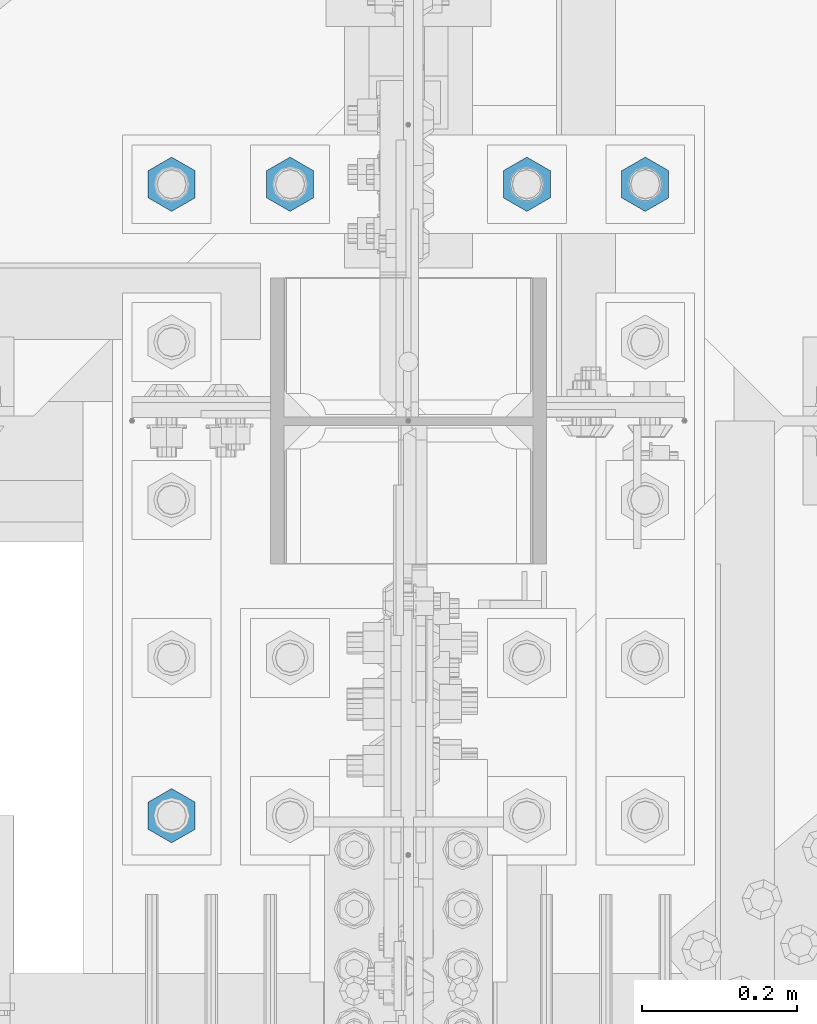
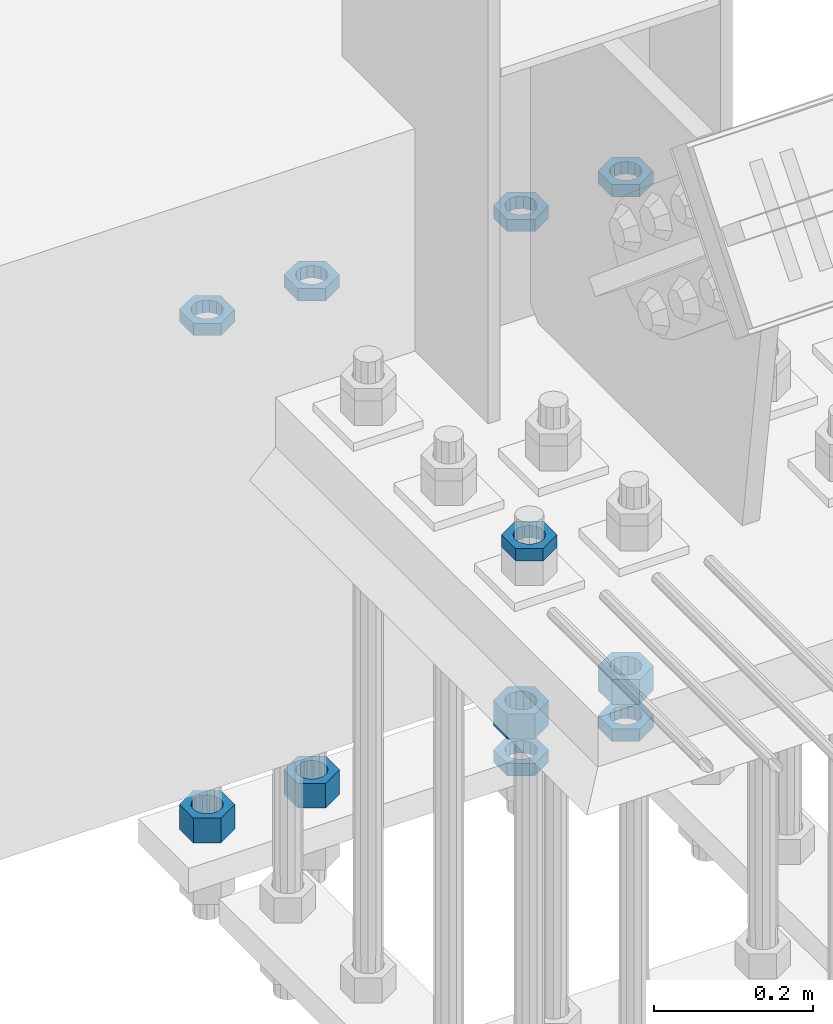
# One storey, part 2843 of 3843: 11 beams, 1 element without a shape of its own.
"""IFC2X3 building model written with IfcOpenShell, lengths in millimetres."""

from ifc_helpers import new_model, si_unit, frame, origin_with_axes, place, context, subcontext, project, spatial, faceted_brep, material, type_object, element, aggregate, save


model = new_model("IFC2X3")

# Units and contexts
model_context = context("Model", 3, precision=1e-05, world=origin_with_axes())
body_context = subcontext(model_context, "Body", "Model", "MODEL_VIEW")
ifc_project = project(units=[si_unit("LENGTHUNIT", "METRE", prefix="MILLI"), si_unit("AREAUNIT", "SQUARE_METRE"), si_unit("VOLUMEUNIT", "CUBIC_METRE"), si_unit("MASSUNIT", "GRAM", prefix="KILO"), si_unit("TIMEUNIT", "SECOND"), si_unit("PLANEANGLEUNIT", "RADIAN"), si_unit("SOLIDANGLEUNIT", "STERADIAN"), si_unit("THERMODYNAMICTEMPERATUREUNIT", "DEGREE_CELSIUS"), si_unit("LUMINOUSINTENSITYUNIT", "LUMEN")], contexts=[model_context])

# Site, building, storey
site_placement = place(None, origin_with_axes())
site = spatial("IfcSite", under=ifc_project, at=site_placement, CompositionType="ELEMENT")
building_placement = place(site_placement, origin_with_axes())
building = spatial("IfcBuilding", under=site, at=building_placement, Name="Undefined", CompositionType="ELEMENT")
storey_placement = place(building_placement, origin_with_axes())
storey = spatial("IfcBuildingStorey", under=building, at=storey_placement, Name="Undefined", CompositionType="ELEMENT", Elevation=0.0)

# Assembly, beams
assembly_placement = place(storey_placement, origin_with_axes())
assembly = element("IfcElementAssembly", 1, at=assembly_placement, inside=storey, Name="TEMPLATE", AssemblyPlace="NOTDEFINED", PredefinedType="RIGID_FRAME")
ifc_material = material(Name="STEEL/A572-50")
beam_type_1 = type_object("IfcBeamType", Name="1-1/2_HEAVY_HEX_NUT", PredefinedType="NOTDEFINED")
beam_1_placement = place(assembly_placement, frame((76708.0, 25920.7, 29298.9000015259), z_axis=(1.0, 0.0, 0.0), x_axis=(0.0, 0.0, -1.0)))
beam_1 = element("IfcBeam", 2, at=beam_1_placement, type_object=beam_type_1, material=ifc_material, Name="NUT", ObjectType="1-1/2_HEAVY_HEX_NUT", context=body_context, shape_type="Brep", body=[
    faceted_brep([(0.0, -34.9199981689453, 0.0), (0.0, -17.4599990844727, -30.25), (38.0999999999985, -17.4599990844727, -30.25), (38.0999999999985, -34.9199981689453, 0.0), (0.0, 17.4599990844727, -30.25), (38.0999999999985, 17.4599990844727, -30.25), (0.0, 34.9199981689453, 0.0), (38.0999999999985, 34.9199981689453, 0.0), (0.0, 17.4599990844727, 30.25), (38.0999999999985, 17.4599990844727, 30.25), (0.0, -17.4599990844727, 30.25), (38.0999999999985, -17.4599990844727, 30.25), (0.0, 0.0, 20.6399993896484), (0.0, 8.9553601105581, 18.5959968835959), (38.0999999999985, 8.9553601105581, 18.5959968835959), (38.0999999999985, 0.0, 20.6399993896484), (0.0, 16.1370013209525, 12.8688291298167), (38.0999999999985, 16.1370013209525, 12.8688291298167), (0.0, 20.1225115123816, 4.59283194104501), (38.0999999999985, 20.1225115123816, 4.59283194104501), (0.0, 20.1225115123816, -4.59283194104501), (38.0999999999985, 20.1225115123816, -4.59283194104501), (0.0, 16.1370013209525, -12.8688291298167), (38.0999999999985, 16.1370013209525, -12.8688291298167), (0.0, 8.9553601105581, -18.5959968835959), (38.0999999999985, 8.9553601105581, -18.5959968835959), (0.0, 0.0, -20.6399993896484), (38.0999999999985, 0.0, -20.6399993896484), (0.0, -8.9553601105581, -18.5959968835959), (38.0999999999985, -8.9553601105581, -18.5959968835959), (0.0, -16.1370013209525, -12.8688291298167), (38.0999999999985, -16.1370013209525, -12.8688291298167), (0.0, -20.1225115123816, -4.59283194104501), (38.0999999999985, -20.1225115123816, -4.59283194104501), (0.0, -20.1225115123816, 4.59283194104501), (38.0999999999985, -20.1225115123816, 4.59283194104501), (0.0, -16.1370013209525, 12.8688291298167), (38.0999999999985, -16.1370013209525, 12.8688291298167), (0.0, -8.9553601105581, 18.5959968835959), (38.0999999999985, -8.9553601105581, 18.5959968835959)], [[[0, 1, 2, 3]], [[1, 4, 5, 2]], [[4, 6, 7, 5]], [[6, 8, 9, 7]], [[8, 10, 11, 9]], [[10, 0, 3, 11]], [[12, 13, 14, 15]], [[13, 16, 17, 14]], [[16, 18, 19, 17]], [[18, 20, 21, 19]], [[20, 22, 23, 21]], [[22, 24, 25, 23]], [[24, 26, 27, 25]], [[26, 28, 29, 27]], [[28, 30, 31, 29]], [[30, 32, 33, 31]], [[32, 34, 35, 33]], [[34, 36, 37, 35]], [[36, 38, 39, 37]], [[38, 12, 15, 39]], [[5, 7, 9, 11, 3, 2], [17, 19, 21, 23, 25, 27, 29, 31, 33, 35, 37, 39, 15, 14]], [[10, 8, 6, 4, 1, 0], [38, 36, 34, 32, 30, 28, 26, 24, 22, 20, 18, 16, 13, 12]]]),
])
beam_2_placement = place(assembly_placement, frame((76860.4, 25920.7, 29298.9000015259), z_axis=(1.0, 0.0, 0.0), x_axis=(0.0, 0.0, -1.0)))
beam_2 = element("IfcBeam", 3, at=beam_2_placement, type_object=beam_type_1, material=ifc_material, Name="NUT", ObjectType="1-1/2_HEAVY_HEX_NUT", context=body_context, shape_type="Brep", body=[
    faceted_brep([(0.0, -34.9199981689453, 0.0), (0.0, -17.4599990844727, -30.25), (38.0999999999985, -17.4599990844727, -30.25), (38.0999999999985, -34.9199981689453, 0.0), (0.0, 17.4599990844727, -30.25), (38.0999999999985, 17.4599990844727, -30.25), (0.0, 34.9199981689453, 0.0), (38.0999999999985, 34.9199981689453, 0.0), (0.0, 17.4599990844727, 30.25), (38.0999999999985, 17.4599990844727, 30.25), (0.0, -17.4599990844727, 30.25), (38.0999999999985, -17.4599990844727, 30.25), (0.0, 0.0, 20.6399993896484), (0.0, 8.9553601105581, 18.5959968835959), (38.0999999999985, 8.9553601105581, 18.5959968835959), (38.0999999999985, 0.0, 20.6399993896484), (0.0, 16.1370013209525, 12.8688291298167), (38.0999999999985, 16.1370013209525, 12.8688291298167), (0.0, 20.1225115123816, 4.59283194104501), (38.0999999999985, 20.1225115123816, 4.59283194104501), (0.0, 20.1225115123816, -4.59283194104501), (38.0999999999985, 20.1225115123816, -4.59283194104501), (0.0, 16.1370013209525, -12.8688291298167), (38.0999999999985, 16.1370013209525, -12.8688291298167), (0.0, 8.9553601105581, -18.5959968835959), (38.0999999999985, 8.9553601105581, -18.5959968835959), (0.0, 0.0, -20.6399993896484), (38.0999999999985, 0.0, -20.6399993896484), (0.0, -8.9553601105581, -18.5959968835959), (38.0999999999985, -8.9553601105581, -18.5959968835959), (0.0, -16.1370013209525, -12.8688291298167), (38.0999999999985, -16.1370013209525, -12.8688291298167), (0.0, -20.1225115123816, -4.59283194104501), (38.0999999999985, -20.1225115123816, -4.59283194104501), (0.0, -20.1225115123816, 4.59283194104501), (38.0999999999985, -20.1225115123816, 4.59283194104501), (0.0, -16.1370013209525, 12.8688291298167), (38.0999999999985, -16.1370013209525, 12.8688291298167), (0.0, -8.9553601105581, 18.5959968835959), (38.0999999999985, -8.9553601105581, 18.5959968835959)], [[[0, 1, 2, 3]], [[1, 4, 5, 2]], [[4, 6, 7, 5]], [[6, 8, 9, 7]], [[8, 10, 11, 9]], [[10, 0, 3, 11]], [[12, 13, 14, 15]], [[13, 16, 17, 14]], [[16, 18, 19, 17]], [[18, 20, 21, 19]], [[20, 22, 23, 21]], [[22, 24, 25, 23]], [[24, 26, 27, 25]], [[26, 28, 29, 27]], [[28, 30, 31, 29]], [[30, 32, 33, 31]], [[32, 34, 35, 33]], [[34, 36, 37, 35]], [[36, 38, 39, 37]], [[38, 12, 15, 39]], [[5, 7, 9, 11, 3, 2], [17, 19, 21, 23, 25, 27, 29, 31, 33, 35, 37, 39, 15, 14]], [[10, 8, 6, 4, 1, 0], [38, 36, 34, 32, 30, 28, 26, 24, 22, 20, 18, 16, 13, 12]]]),
])
beam_3_placement = place(assembly_placement, frame((77165.2, 25920.7, 29298.9000015259), z_axis=(1.0, 0.0, 0.0), x_axis=(0.0, 0.0, -1.0)))
beam_3 = element("IfcBeam", 4, at=beam_3_placement, type_object=beam_type_1, material=ifc_material, Name="NUT", ObjectType="1-1/2_HEAVY_HEX_NUT", context=body_context, shape_type="Brep", body=[
    faceted_brep([(0.0, -34.9199981689453, 0.0), (0.0, -17.4599990844727, -30.25), (38.0999999999985, -17.4599990844727, -30.25), (38.0999999999985, -34.9199981689453, 0.0), (0.0, 17.4599990844727, -30.25), (38.0999999999985, 17.4599990844727, -30.25), (0.0, 34.9199981689453, 0.0), (38.0999999999985, 34.9199981689453, 0.0), (0.0, 17.4599990844727, 30.25), (38.0999999999985, 17.4599990844727, 30.25), (0.0, -17.4599990844727, 30.25), (38.0999999999985, -17.4599990844727, 30.25), (0.0, 0.0, 20.6399993896484), (0.0, 8.9553601105581, 18.5959968835959), (38.0999999999985, 8.9553601105581, 18.5959968835959), (38.0999999999985, 0.0, 20.6399993896484), (0.0, 16.1370013209525, 12.8688291298167), (38.0999999999985, 16.1370013209525, 12.8688291298167), (0.0, 20.1225115123816, 4.59283194104501), (38.0999999999985, 20.1225115123816, 4.59283194104501), (0.0, 20.1225115123816, -4.59283194104501), (38.0999999999985, 20.1225115123816, -4.59283194104501), (0.0, 16.1370013209525, -12.8688291298167), (38.0999999999985, 16.1370013209525, -12.8688291298167), (0.0, 8.9553601105581, -18.5959968835959), (38.0999999999985, 8.9553601105581, -18.5959968835959), (0.0, 0.0, -20.6399993896484), (38.0999999999985, 0.0, -20.6399993896484), (0.0, -8.9553601105581, -18.5959968835959), (38.0999999999985, -8.9553601105581, -18.5959968835959), (0.0, -16.1370013209525, -12.8688291298167), (38.0999999999985, -16.1370013209525, -12.8688291298167), (0.0, -20.1225115123816, -4.59283194104501), (38.0999999999985, -20.1225115123816, -4.59283194104501), (0.0, -20.1225115123816, 4.59283194104501), (38.0999999999985, -20.1225115123816, 4.59283194104501), (0.0, -16.1370013209525, 12.8688291298167), (38.0999999999985, -16.1370013209525, 12.8688291298167), (0.0, -8.9553601105581, 18.5959968835959), (38.0999999999985, -8.9553601105581, 18.5959968835959)], [[[0, 1, 2, 3]], [[1, 4, 5, 2]], [[4, 6, 7, 5]], [[6, 8, 9, 7]], [[8, 10, 11, 9]], [[10, 0, 3, 11]], [[12, 13, 14, 15]], [[13, 16, 17, 14]], [[16, 18, 19, 17]], [[18, 20, 21, 19]], [[20, 22, 23, 21]], [[22, 24, 25, 23]], [[24, 26, 27, 25]], [[26, 28, 29, 27]], [[28, 30, 31, 29]], [[30, 32, 33, 31]], [[32, 34, 35, 33]], [[34, 36, 37, 35]], [[36, 38, 39, 37]], [[38, 12, 15, 39]], [[5, 7, 9, 11, 3, 2], [17, 19, 21, 23, 25, 27, 29, 31, 33, 35, 37, 39, 15, 14]], [[10, 8, 6, 4, 1, 0], [38, 36, 34, 32, 30, 28, 26, 24, 22, 20, 18, 16, 13, 12]]]),
])
beam_4_placement = place(assembly_placement, frame((77317.6, 25920.7, 29298.9000015259), z_axis=(1.0, 0.0, 0.0), x_axis=(0.0, 0.0, -1.0)))
beam_4 = element("IfcBeam", 5, at=beam_4_placement, type_object=beam_type_1, material=ifc_material, Name="NUT", ObjectType="1-1/2_HEAVY_HEX_NUT", context=body_context, shape_type="Brep", body=[
    faceted_brep([(0.0, -34.9199981689453, 0.0), (0.0, -17.4599990844727, -30.25), (38.0999999999985, -17.4599990844727, -30.25), (38.0999999999985, -34.9199981689453, 0.0), (0.0, 17.4599990844727, -30.25), (38.0999999999985, 17.4599990844727, -30.25), (0.0, 34.9199981689453, 0.0), (38.0999999999985, 34.9199981689453, 0.0), (0.0, 17.4599990844727, 30.25), (38.0999999999985, 17.4599990844727, 30.25), (0.0, -17.4599990844727, 30.25), (38.0999999999985, -17.4599990844727, 30.25), (0.0, 0.0, 20.6399993896484), (0.0, 8.9553601105581, 18.5959968835959), (38.0999999999985, 8.9553601105581, 18.5959968835959), (38.0999999999985, 0.0, 20.6399993896484), (0.0, 16.1370013209525, 12.8688291298167), (38.0999999999985, 16.1370013209525, 12.8688291298167), (0.0, 20.1225115123816, 4.59283194104501), (38.0999999999985, 20.1225115123816, 4.59283194104501), (0.0, 20.1225115123816, -4.59283194104501), (38.0999999999985, 20.1225115123816, -4.59283194104501), (0.0, 16.1370013209525, -12.8688291298167), (38.0999999999985, 16.1370013209525, -12.8688291298167), (0.0, 8.9553601105581, -18.5959968835959), (38.0999999999985, 8.9553601105581, -18.5959968835959), (0.0, 0.0, -20.6399993896484), (38.0999999999985, 0.0, -20.6399993896484), (0.0, -8.9553601105581, -18.5959968835959), (38.0999999999985, -8.9553601105581, -18.5959968835959), (0.0, -16.1370013209525, -12.8688291298167), (38.0999999999985, -16.1370013209525, -12.8688291298167), (0.0, -20.1225115123816, -4.59283194104501), (38.0999999999985, -20.1225115123816, -4.59283194104501), (0.0, -20.1225115123816, 4.59283194104501), (38.0999999999985, -20.1225115123816, 4.59283194104501), (0.0, -16.1370013209525, 12.8688291298167), (38.0999999999985, -16.1370013209525, 12.8688291298167), (0.0, -8.9553601105581, 18.5959968835959), (38.0999999999985, -8.9553601105581, 18.5959968835959)], [[[0, 1, 2, 3]], [[1, 4, 5, 2]], [[4, 6, 7, 5]], [[6, 8, 9, 7]], [[8, 10, 11, 9]], [[10, 0, 3, 11]], [[12, 13, 14, 15]], [[13, 16, 17, 14]], [[16, 18, 19, 17]], [[18, 20, 21, 19]], [[20, 22, 23, 21]], [[22, 24, 25, 23]], [[24, 26, 27, 25]], [[26, 28, 29, 27]], [[28, 30, 31, 29]], [[30, 32, 33, 31]], [[32, 34, 35, 33]], [[34, 36, 37, 35]], [[36, 38, 39, 37]], [[38, 12, 15, 39]], [[5, 7, 9, 11, 3, 2], [17, 19, 21, 23, 25, 27, 29, 31, 33, 35, 37, 39, 15, 14]], [[10, 8, 6, 4, 1, 0], [38, 36, 34, 32, 30, 28, 26, 24, 22, 20, 18, 16, 13, 12]]]),
])
beam_type_2 = type_object("IfcBeamType", Name="1-1/2_HALF_NUT", PredefinedType="NOTDEFINED")
beam_5_placement = place(assembly_placement, frame((77165.2, 25920.7, 30060.9), z_axis=(1.0, 0.0, 0.0), x_axis=(0.0, 0.0, -1.0)))
beam_5 = element("IfcBeam", 6, at=beam_5_placement, type_object=beam_type_2, material=ifc_material, Name="NUT", ObjectType="1-1/2_HALF_NUT", context=body_context, shape_type="Brep", body=[
    faceted_brep([(0.0, -34.9199981689453, 0.0), (0.0, -17.4599990844727, -30.25), (19.0500000000029, -17.4599990844727, -30.25), (19.0500000000029, -34.9199981689453, 0.0), (0.0, 17.4599990844727, -30.25), (19.0500000000029, 17.4599990844727, -30.25), (0.0, 34.9199981689453, 0.0), (19.0500000000029, 34.9199981689453, 0.0), (0.0, 17.4599990844727, 30.25), (19.0500000000029, 17.4599990844727, 30.25), (0.0, -17.4599990844727, 30.25), (19.0500000000029, -17.4599990844727, 30.25), (0.0, 0.0, 20.6399993896484), (0.0, 8.9553601105581, 18.5959968835959), (19.0500000000029, 8.95536011056538, 18.5959968835959), (19.0500000000029, 0.0, 20.6399993896484), (0.0, 16.1370013209525, 12.8688291298167), (19.0500000000029, 16.1370013209489, 12.8688291298167), (0.0, 20.1225115123816, 4.59283194104501), (19.0500000000029, 20.1225115123852, 4.59283194104501), (0.0, 20.1225115123816, -4.59283194104501), (19.0500000000029, 20.1225115123852, -4.59283194104501), (0.0, 16.1370013209525, -12.8688291298167), (19.0500000000029, 16.1370013209489, -12.8688291298167), (0.0, 8.9553601105581, -18.5959968835959), (19.0500000000029, 8.95536011056538, -18.5959968835959), (0.0, 0.0, -20.6399993896484), (19.0500000000029, 0.0, -20.6399993896484), (0.0, -8.9553601105581, -18.5959968835959), (19.0500000000029, -8.95536011056538, -18.5959968835959), (0.0, -16.1370013209525, -12.8688291298167), (19.0500000000029, -16.1370013209489, -12.8688291298167), (0.0, -20.1225115123816, -4.59283194104501), (19.0500000000029, -20.1225115123852, -4.59283194104501), (0.0, -20.1225115123816, 4.59283194104501), (19.0500000000029, -20.1225115123852, 4.59283194104501), (0.0, -16.1370013209525, 12.8688291298167), (19.0500000000029, -16.1370013209489, 12.8688291298167), (0.0, -8.9553601105581, 18.5959968835959), (19.0500000000029, -8.95536011056538, 18.5959968835959)], [[[0, 1, 2, 3]], [[1, 4, 5, 2]], [[4, 6, 7, 5]], [[6, 8, 9, 7]], [[8, 10, 11, 9]], [[10, 0, 3, 11]], [[12, 13, 14, 15]], [[13, 16, 17, 14]], [[16, 18, 19, 17]], [[18, 20, 21, 19]], [[20, 22, 23, 21]], [[22, 24, 25, 23]], [[24, 26, 27, 25]], [[26, 28, 29, 27]], [[28, 30, 31, 29]], [[30, 32, 33, 31]], [[32, 34, 35, 33]], [[34, 36, 37, 35]], [[36, 38, 39, 37]], [[38, 12, 15, 39]], [[5, 7, 9, 11, 3, 2], [17, 19, 21, 23, 25, 27, 29, 31, 33, 35, 37, 39, 15, 14]], [[10, 8, 6, 4, 1, 0], [38, 36, 34, 32, 30, 28, 26, 24, 22, 20, 18, 16, 13, 12]]]),
])
beam_6_placement = place(assembly_placement, frame((77317.6, 25920.7, 30060.9), z_axis=(1.0, 0.0, 0.0), x_axis=(0.0, 0.0, -1.0)))
beam_6 = element("IfcBeam", 7, at=beam_6_placement, type_object=beam_type_2, material=ifc_material, Name="NUT", ObjectType="1-1/2_HALF_NUT", context=body_context, shape_type="Brep", body=[
    faceted_brep([(0.0, -34.9199981689453, 0.0), (0.0, -17.4599990844727, -30.25), (19.0500000000029, -17.4599990844727, -30.25), (19.0500000000029, -34.9199981689453, 0.0), (0.0, 17.4599990844727, -30.25), (19.0500000000029, 17.4599990844727, -30.25), (0.0, 34.9199981689453, 0.0), (19.0500000000029, 34.9199981689453, 0.0), (0.0, 17.4599990844727, 30.25), (19.0500000000029, 17.4599990844727, 30.25), (0.0, -17.4599990844727, 30.25), (19.0500000000029, -17.4599990844727, 30.25), (0.0, 0.0, 20.6399993896484), (0.0, 8.9553601105581, 18.5959968835959), (19.0500000000029, 8.95536011056538, 18.5959968835959), (19.0500000000029, 0.0, 20.6399993896484), (0.0, 16.1370013209525, 12.8688291298167), (19.0500000000029, 16.1370013209489, 12.8688291298167), (0.0, 20.1225115123816, 4.59283194104501), (19.0500000000029, 20.1225115123852, 4.59283194104501), (0.0, 20.1225115123816, -4.59283194104501), (19.0500000000029, 20.1225115123852, -4.59283194104501), (0.0, 16.1370013209525, -12.8688291298167), (19.0500000000029, 16.1370013209489, -12.8688291298167), (0.0, 8.9553601105581, -18.5959968835959), (19.0500000000029, 8.95536011056538, -18.5959968835959), (0.0, 0.0, -20.6399993896484), (19.0500000000029, 0.0, -20.6399993896484), (0.0, -8.9553601105581, -18.5959968835959), (19.0500000000029, -8.95536011056538, -18.5959968835959), (0.0, -16.1370013209525, -12.8688291298167), (19.0500000000029, -16.1370013209489, -12.8688291298167), (0.0, -20.1225115123816, -4.59283194104501), (19.0500000000029, -20.1225115123852, -4.59283194104501), (0.0, -20.1225115123816, 4.59283194104501), (19.0500000000029, -20.1225115123852, 4.59283194104501), (0.0, -16.1370013209525, 12.8688291298167), (19.0500000000029, -16.1370013209489, 12.8688291298167), (0.0, -8.9553601105581, 18.5959968835959), (19.0500000000029, -8.95536011056538, 18.5959968835959)], [[[0, 1, 2, 3]], [[1, 4, 5, 2]], [[4, 6, 7, 5]], [[6, 8, 9, 7]], [[8, 10, 11, 9]], [[10, 0, 3, 11]], [[12, 13, 14, 15]], [[13, 16, 17, 14]], [[16, 18, 19, 17]], [[18, 20, 21, 19]], [[20, 22, 23, 21]], [[22, 24, 25, 23]], [[24, 26, 27, 25]], [[26, 28, 29, 27]], [[28, 30, 31, 29]], [[30, 32, 33, 31]], [[32, 34, 35, 33]], [[34, 36, 37, 35]], [[36, 38, 39, 37]], [[38, 12, 15, 39]], [[5, 7, 9, 11, 3, 2], [17, 19, 21, 23, 25, 27, 29, 31, 33, 35, 37, 39, 15, 14]], [[10, 8, 6, 4, 1, 0], [38, 36, 34, 32, 30, 28, 26, 24, 22, 20, 18, 16, 13, 12]]]),
])
beam_7_placement = place(assembly_placement, frame((76860.4, 25920.7, 30060.9), z_axis=(1.0, 0.0, 0.0), x_axis=(0.0, 0.0, -1.0)))
beam_7 = element("IfcBeam", 8, at=beam_7_placement, type_object=beam_type_2, material=ifc_material, Name="NUT", ObjectType="1-1/2_HALF_NUT", context=body_context, shape_type="Brep", body=[
    faceted_brep([(0.0, -34.9199981689453, 0.0), (0.0, -17.4599990844727, -30.25), (19.0500000000029, -17.4599990844727, -30.25), (19.0500000000029, -34.9199981689453, 0.0), (0.0, 17.4599990844727, -30.25), (19.0500000000029, 17.4599990844727, -30.25), (0.0, 34.9199981689453, 0.0), (19.0500000000029, 34.9199981689453, 0.0), (0.0, 17.4599990844727, 30.25), (19.0500000000029, 17.4599990844727, 30.25), (0.0, -17.4599990844727, 30.25), (19.0500000000029, -17.4599990844727, 30.25), (0.0, 0.0, 20.6399993896484), (0.0, 8.9553601105581, 18.5959968835959), (19.0500000000029, 8.95536011056538, 18.5959968835959), (19.0500000000029, 0.0, 20.6399993896484), (0.0, 16.1370013209525, 12.8688291298167), (19.0500000000029, 16.1370013209489, 12.8688291298167), (0.0, 20.1225115123816, 4.59283194104501), (19.0500000000029, 20.1225115123852, 4.59283194104501), (0.0, 20.1225115123816, -4.59283194104501), (19.0500000000029, 20.1225115123852, -4.59283194104501), (0.0, 16.1370013209525, -12.8688291298167), (19.0500000000029, 16.1370013209489, -12.8688291298167), (0.0, 8.9553601105581, -18.5959968835959), (19.0500000000029, 8.95536011056538, -18.5959968835959), (0.0, 0.0, -20.6399993896484), (19.0500000000029, 0.0, -20.6399993896484), (0.0, -8.9553601105581, -18.5959968835959), (19.0500000000029, -8.95536011056538, -18.5959968835959), (0.0, -16.1370013209525, -12.8688291298167), (19.0500000000029, -16.1370013209489, -12.8688291298167), (0.0, -20.1225115123816, -4.59283194104501), (19.0500000000029, -20.1225115123852, -4.59283194104501), (0.0, -20.1225115123816, 4.59283194104501), (19.0500000000029, -20.1225115123852, 4.59283194104501), (0.0, -16.1370013209525, 12.8688291298167), (19.0500000000029, -16.1370013209489, 12.8688291298167), (0.0, -8.9553601105581, 18.5959968835959), (19.0500000000029, -8.95536011056538, 18.5959968835959)], [[[0, 1, 2, 3]], [[1, 4, 5, 2]], [[4, 6, 7, 5]], [[6, 8, 9, 7]], [[8, 10, 11, 9]], [[10, 0, 3, 11]], [[12, 13, 14, 15]], [[13, 16, 17, 14]], [[16, 18, 19, 17]], [[18, 20, 21, 19]], [[20, 22, 23, 21]], [[22, 24, 25, 23]], [[24, 26, 27, 25]], [[26, 28, 29, 27]], [[28, 30, 31, 29]], [[30, 32, 33, 31]], [[32, 34, 35, 33]], [[34, 36, 37, 35]], [[36, 38, 39, 37]], [[38, 12, 15, 39]], [[5, 7, 9, 11, 3, 2], [17, 19, 21, 23, 25, 27, 29, 31, 33, 35, 37, 39, 15, 14]], [[10, 8, 6, 4, 1, 0], [38, 36, 34, 32, 30, 28, 26, 24, 22, 20, 18, 16, 13, 12]]]),
])
beam_8_placement = place(assembly_placement, frame((76708.0, 25920.7, 30060.9), z_axis=(1.0, 0.0, 0.0), x_axis=(0.0, 0.0, -1.0)))
beam_8 = element("IfcBeam", 9, at=beam_8_placement, type_object=beam_type_2, material=ifc_material, Name="NUT", ObjectType="1-1/2_HALF_NUT", context=body_context, shape_type="Brep", body=[
    faceted_brep([(0.0, -34.9199981689453, 0.0), (0.0, -17.4599990844727, -30.25), (19.0500000000029, -17.4599990844727, -30.25), (19.0500000000029, -34.9199981689453, 0.0), (0.0, 17.4599990844727, -30.25), (19.0500000000029, 17.4599990844727, -30.25), (0.0, 34.9199981689453, 0.0), (19.0500000000029, 34.9199981689453, 0.0), (0.0, 17.4599990844727, 30.25), (19.0500000000029, 17.4599990844727, 30.25), (0.0, -17.4599990844727, 30.25), (19.0500000000029, -17.4599990844727, 30.25), (0.0, 0.0, 20.6399993896484), (0.0, 8.9553601105581, 18.5959968835959), (19.0500000000029, 8.95536011056538, 18.5959968835959), (19.0500000000029, 0.0, 20.6399993896484), (0.0, 16.1370013209525, 12.8688291298167), (19.0500000000029, 16.1370013209489, 12.8688291298167), (0.0, 20.1225115123816, 4.59283194104501), (19.0500000000029, 20.1225115123852, 4.59283194104501), (0.0, 20.1225115123816, -4.59283194104501), (19.0500000000029, 20.1225115123852, -4.59283194104501), (0.0, 16.1370013209525, -12.8688291298167), (19.0500000000029, 16.1370013209489, -12.8688291298167), (0.0, 8.9553601105581, -18.5959968835959), (19.0500000000029, 8.95536011056538, -18.5959968835959), (0.0, 0.0, -20.6399993896484), (19.0500000000029, 0.0, -20.6399993896484), (0.0, -8.9553601105581, -18.5959968835959), (19.0500000000029, -8.95536011056538, -18.5959968835959), (0.0, -16.1370013209525, -12.8688291298167), (19.0500000000029, -16.1370013209489, -12.8688291298167), (0.0, -20.1225115123816, -4.59283194104501), (19.0500000000029, -20.1225115123852, -4.59283194104501), (0.0, -20.1225115123816, 4.59283194104501), (19.0500000000029, -20.1225115123852, 4.59283194104501), (0.0, -16.1370013209525, 12.8688291298167), (19.0500000000029, -16.1370013209489, 12.8688291298167), (0.0, -8.9553601105581, 18.5959968835959), (19.0500000000029, -8.95536011056538, 18.5959968835959)], [[[0, 1, 2, 3]], [[1, 4, 5, 2]], [[4, 6, 7, 5]], [[6, 8, 9, 7]], [[8, 10, 11, 9]], [[10, 0, 3, 11]], [[12, 13, 14, 15]], [[13, 16, 17, 14]], [[16, 18, 19, 17]], [[18, 20, 21, 19]], [[20, 22, 23, 21]], [[22, 24, 25, 23]], [[24, 26, 27, 25]], [[26, 28, 29, 27]], [[28, 30, 31, 29]], [[30, 32, 33, 31]], [[32, 34, 35, 33]], [[34, 36, 37, 35]], [[36, 38, 39, 37]], [[38, 12, 15, 39]], [[5, 7, 9, 11, 3, 2], [17, 19, 21, 23, 25, 27, 29, 31, 33, 35, 37, 39, 15, 14]], [[10, 8, 6, 4, 1, 0], [38, 36, 34, 32, 30, 28, 26, 24, 22, 20, 18, 16, 13, 12]]]),
])
beam_9_placement = place(assembly_placement, frame((77317.6, 25920.7, 29222.7000015259), z_axis=(1.0, 0.0, 0.0), x_axis=(0.0, 0.0, -1.0)))
beam_9 = element("IfcBeam", 10, at=beam_9_placement, type_object=beam_type_2, material=ifc_material, Name="NUT", ObjectType="1-1/2_HALF_NUT", context=body_context, shape_type="Brep", body=[
    faceted_brep([(0.0, -34.9199981689453, 0.0), (0.0, -17.4599990844727, -30.25), (19.0500000000029, -17.4599990844727, -30.25), (19.0500000000029, -34.9199981689453, 0.0), (0.0, 17.4599990844727, -30.25), (19.0500000000029, 17.4599990844727, -30.25), (0.0, 34.9199981689453, 0.0), (19.0500000000029, 34.9199981689453, 0.0), (0.0, 17.4599990844727, 30.25), (19.0500000000029, 17.4599990844727, 30.25), (0.0, -17.4599990844727, 30.25), (19.0500000000029, -17.4599990844727, 30.25), (0.0, 0.0, 20.6399993896484), (0.0, 8.9553601105581, 18.5959968835959), (19.0500000000029, 8.95536011056538, 18.5959968835959), (19.0500000000029, 0.0, 20.6399993896484), (0.0, 16.1370013209525, 12.8688291298167), (19.0500000000029, 16.1370013209489, 12.8688291298167), (0.0, 20.1225115123816, 4.59283194104501), (19.0500000000029, 20.1225115123852, 4.59283194104501), (0.0, 20.1225115123816, -4.59283194104501), (19.0500000000029, 20.1225115123852, -4.59283194104501), (0.0, 16.1370013209525, -12.8688291298167), (19.0500000000029, 16.1370013209489, -12.8688291298167), (0.0, 8.9553601105581, -18.5959968835959), (19.0500000000029, 8.95536011056538, -18.5959968835959), (0.0, 0.0, -20.6399993896484), (19.0500000000029, 0.0, -20.6399993896484), (0.0, -8.9553601105581, -18.5959968835959), (19.0500000000029, -8.95536011056538, -18.5959968835959), (0.0, -16.1370013209525, -12.8688291298167), (19.0500000000029, -16.1370013209489, -12.8688291298167), (0.0, -20.1225115123816, -4.59283194104501), (19.0500000000029, -20.1225115123852, -4.59283194104501), (0.0, -20.1225115123816, 4.59283194104501), (19.0500000000029, -20.1225115123852, 4.59283194104501), (0.0, -16.1370013209525, 12.8688291298167), (19.0500000000029, -16.1370013209489, 12.8688291298167), (0.0, -8.9553601105581, 18.5959968835959), (19.0500000000029, -8.95536011056538, 18.5959968835959)], [[[0, 1, 2, 3]], [[1, 4, 5, 2]], [[4, 6, 7, 5]], [[6, 8, 9, 7]], [[8, 10, 11, 9]], [[10, 0, 3, 11]], [[12, 13, 14, 15]], [[13, 16, 17, 14]], [[16, 18, 19, 17]], [[18, 20, 21, 19]], [[20, 22, 23, 21]], [[22, 24, 25, 23]], [[24, 26, 27, 25]], [[26, 28, 29, 27]], [[28, 30, 31, 29]], [[30, 32, 33, 31]], [[32, 34, 35, 33]], [[34, 36, 37, 35]], [[36, 38, 39, 37]], [[38, 12, 15, 39]], [[5, 7, 9, 11, 3, 2], [17, 19, 21, 23, 25, 27, 29, 31, 33, 35, 37, 39, 15, 14]], [[10, 8, 6, 4, 1, 0], [38, 36, 34, 32, 30, 28, 26, 24, 22, 20, 18, 16, 13, 12]]]),
])
beam_10_placement = place(assembly_placement, frame((77165.2, 25920.7, 29222.7000015259), z_axis=(1.0, 0.0, 0.0), x_axis=(0.0, 0.0, -1.0)))
beam_10 = element("IfcBeam", 11, at=beam_10_placement, type_object=beam_type_2, material=ifc_material, Name="NUT", ObjectType="1-1/2_HALF_NUT", context=body_context, shape_type="Brep", body=[
    faceted_brep([(0.0, -34.9199981689453, 0.0), (0.0, -17.4599990844727, -30.25), (19.0500000000029, -17.4599990844727, -30.25), (19.0500000000029, -34.9199981689453, 0.0), (0.0, 17.4599990844727, -30.25), (19.0500000000029, 17.4599990844727, -30.25), (0.0, 34.9199981689453, 0.0), (19.0500000000029, 34.9199981689453, 0.0), (0.0, 17.4599990844727, 30.25), (19.0500000000029, 17.4599990844727, 30.25), (0.0, -17.4599990844727, 30.25), (19.0500000000029, -17.4599990844727, 30.25), (0.0, 0.0, 20.6399993896484), (0.0, 8.9553601105581, 18.5959968835959), (19.0500000000029, 8.95536011056538, 18.5959968835959), (19.0500000000029, 0.0, 20.6399993896484), (0.0, 16.1370013209525, 12.8688291298167), (19.0500000000029, 16.1370013209489, 12.8688291298167), (0.0, 20.1225115123816, 4.59283194104501), (19.0500000000029, 20.1225115123852, 4.59283194104501), (0.0, 20.1225115123816, -4.59283194104501), (19.0500000000029, 20.1225115123852, -4.59283194104501), (0.0, 16.1370013209525, -12.8688291298167), (19.0500000000029, 16.1370013209489, -12.8688291298167), (0.0, 8.9553601105581, -18.5959968835959), (19.0500000000029, 8.95536011056538, -18.5959968835959), (0.0, 0.0, -20.6399993896484), (19.0500000000029, 0.0, -20.6399993896484), (0.0, -8.9553601105581, -18.5959968835959), (19.0500000000029, -8.95536011056538, -18.5959968835959), (0.0, -16.1370013209525, -12.8688291298167), (19.0500000000029, -16.1370013209489, -12.8688291298167), (0.0, -20.1225115123816, -4.59283194104501), (19.0500000000029, -20.1225115123852, -4.59283194104501), (0.0, -20.1225115123816, 4.59283194104501), (19.0500000000029, -20.1225115123852, 4.59283194104501), (0.0, -16.1370013209525, 12.8688291298167), (19.0500000000029, -16.1370013209489, 12.8688291298167), (0.0, -8.9553601105581, 18.5959968835959), (19.0500000000029, -8.95536011056538, 18.5959968835959)], [[[0, 1, 2, 3]], [[1, 4, 5, 2]], [[4, 6, 7, 5]], [[6, 8, 9, 7]], [[8, 10, 11, 9]], [[10, 0, 3, 11]], [[12, 13, 14, 15]], [[13, 16, 17, 14]], [[16, 18, 19, 17]], [[18, 20, 21, 19]], [[20, 22, 23, 21]], [[22, 24, 25, 23]], [[24, 26, 27, 25]], [[26, 28, 29, 27]], [[28, 30, 31, 29]], [[30, 32, 33, 31]], [[32, 34, 35, 33]], [[34, 36, 37, 35]], [[36, 38, 39, 37]], [[38, 12, 15, 39]], [[5, 7, 9, 11, 3, 2], [17, 19, 21, 23, 25, 27, 29, 31, 33, 35, 37, 39, 15, 14]], [[10, 8, 6, 4, 1, 0], [38, 36, 34, 32, 30, 28, 26, 24, 22, 20, 18, 16, 13, 12]]]),
])
beam_11_placement = place(assembly_placement, frame((76708.0, 25107.9, 30206.95), z_axis=(-1.0, 0.0, 0.0), x_axis=(0.0, 0.0, -1.0)))
beam_11 = element("IfcBeam", 12, at=beam_11_placement, type_object=beam_type_2, material=ifc_material, Name="NUT", ObjectType="1-1/2_HALF_NUT", context=body_context, shape_type="Brep", body=[
    faceted_brep([(0.0, -34.9199981689453, 0.0), (0.0, -17.4599990844727, -30.25), (19.0500000000029, -17.4599990844727, -30.25), (19.0500000000029, -34.9199981689453, 0.0), (0.0, 17.4599990844727, -30.25), (19.0500000000029, 17.4599990844727, -30.25), (0.0, 34.9199981689453, 0.0), (19.0500000000029, 34.9199981689453, 0.0), (0.0, 17.4599990844727, 30.25), (19.0500000000029, 17.4599990844727, 30.25), (0.0, -17.4599990844727, 30.25), (19.0500000000029, -17.4599990844727, 30.25), (0.0, 0.0, 20.6399993896484), (0.0, 8.9553601105581, 18.5959968835959), (19.0500000000029, 8.95536011056538, 18.5959968835959), (19.0500000000029, 0.0, 20.6399993896484), (0.0, 16.1370013209525, 12.8688291298167), (19.0500000000029, 16.1370013209489, 12.8688291298167), (0.0, 20.1225115123816, 4.59283194104501), (19.0500000000029, 20.1225115123852, 4.59283194104501), (0.0, 20.1225115123816, -4.59283194104501), (19.0500000000029, 20.1225115123852, -4.59283194104501), (0.0, 16.1370013209525, -12.8688291298167), (19.0500000000029, 16.1370013209489, -12.8688291298167), (0.0, 8.9553601105581, -18.5959968835959), (19.0500000000029, 8.95536011056538, -18.5959968835959), (0.0, 0.0, -20.6399993896484), (19.0500000000029, 0.0, -20.6399993896484), (0.0, -8.9553601105581, -18.5959968835959), (19.0500000000029, -8.95536011056538, -18.5959968835959), (0.0, -16.1370013209525, -12.8688291298167), (19.0500000000029, -16.1370013209489, -12.8688291298167), (0.0, -20.1225115123816, -4.59283194104501), (19.0500000000029, -20.1225115123852, -4.59283194104501), (0.0, -20.1225115123816, 4.59283194104501), (19.0500000000029, -20.1225115123852, 4.59283194104501), (0.0, -16.1370013209525, 12.8688291298167), (19.0500000000029, -16.1370013209489, 12.8688291298167), (0.0, -8.9553601105581, 18.5959968835959), (19.0500000000029, -8.95536011056538, 18.5959968835959)], [[[0, 1, 2, 3]], [[1, 4, 5, 2]], [[4, 6, 7, 5]], [[6, 8, 9, 7]], [[8, 10, 11, 9]], [[10, 0, 3, 11]], [[12, 13, 14, 15]], [[13, 16, 17, 14]], [[16, 18, 19, 17]], [[18, 20, 21, 19]], [[20, 22, 23, 21]], [[22, 24, 25, 23]], [[24, 26, 27, 25]], [[26, 28, 29, 27]], [[28, 30, 31, 29]], [[30, 32, 33, 31]], [[32, 34, 35, 33]], [[34, 36, 37, 35]], [[36, 38, 39, 37]], [[38, 12, 15, 39]], [[5, 7, 9, 11, 3, 2], [17, 19, 21, 23, 25, 27, 29, 31, 33, 35, 37, 39, 15, 14]], [[10, 8, 6, 4, 1, 0], [38, 36, 34, 32, 30, 28, 26, 24, 22, 20, 18, 16, 13, 12]]]),
])
aggregate(assembly, [beam_1, beam_2, beam_3, beam_4, beam_5, beam_6, beam_7, beam_8, beam_9, beam_10, beam_11])

save(model, "model.ifc")
